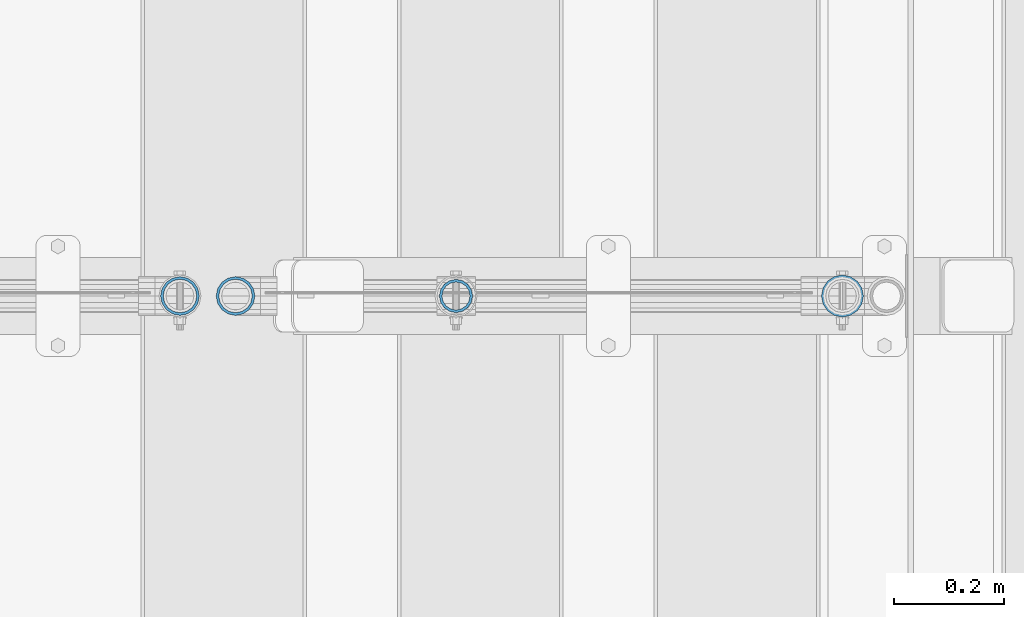
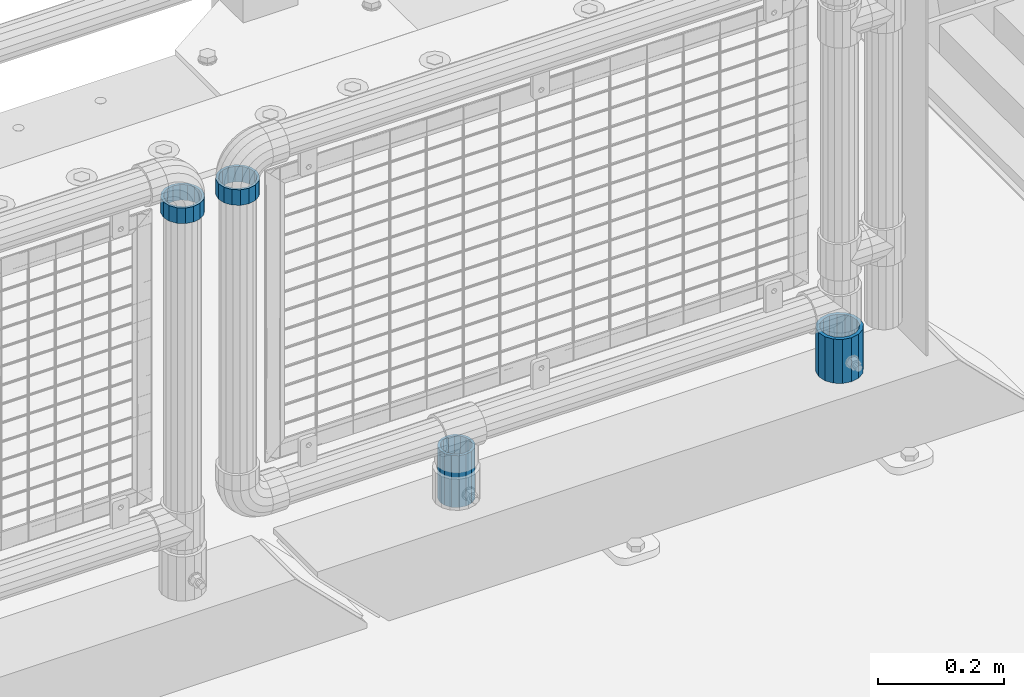
# One storey, part 104 of 247: 4 columns.
"""IFC2X3 building model written with IfcOpenShell, lengths in millimetres."""

from ifc_helpers import new_model, si_unit, frame, origin_with_axes, place, context, subcontext, project, spatial, faceted_brep, material, type_object, element, save


model = new_model("IFC2X3")

# Units and contexts
model_context = context("Model", 3, precision=1e-05, world=origin_with_axes())
body_context = subcontext(model_context, "Body", "Model", "MODEL_VIEW")
ifc_project = project(units=[si_unit("LENGTHUNIT", "METRE", prefix="MILLI"), si_unit("AREAUNIT", "SQUARE_METRE"), si_unit("VOLUMEUNIT", "CUBIC_METRE"), si_unit("MASSUNIT", "GRAM", prefix="KILO"), si_unit("TIMEUNIT", "SECOND"), si_unit("PLANEANGLEUNIT", "RADIAN"), si_unit("SOLIDANGLEUNIT", "STERADIAN"), si_unit("THERMODYNAMICTEMPERATUREUNIT", "DEGREE_CELSIUS"), si_unit("LUMINOUSINTENSITYUNIT", "LUMEN")], contexts=[model_context])

# Site, building, storey
site_placement = place(None, origin_with_axes())
site = spatial("IfcSite", under=ifc_project, at=site_placement, CompositionType="ELEMENT")
building_placement = place(site_placement, origin_with_axes())
building = spatial("IfcBuilding", under=site, at=building_placement, Name="Standard", CompositionType="ELEMENT")
storey_placement = place(building_placement, origin_with_axes())
storey = spatial("IfcBuildingStorey", under=building, at=storey_placement, Name="Undefined", CompositionType="ELEMENT", Elevation=0.0)

# Columns
ifc_material_1 = material()
column_type_1 = type_object("IfcColumnType", PredefinedType="NOTDEFINED")
column_1_placement = place(storey_placement, frame((16221.0, 7664.5, 168.019999999998), z_axis=(0.0, 1.0, 0.0), x_axis=(0.0, 0.0, 1.0)))
element("IfcColumn", 1, at=column_1_placement, inside=storey, type_object=column_type_1, material=ifc_material_1, context=body_context, shape_type="Brep", body=[
    faceted_brep([(0.0, -31.75, 0.0), (0.0, -29.3331751572332, 12.1501989775916), (85.0, -29.3331751572332, 12.1501989775916), (85.0, -31.75, 0.0), (0.0, -22.4506403026735, 22.4506403026726), (85.0, -22.4506403026735, 22.4506403026726), (0.0, -12.1501989775916, 29.3331751572332), (85.0, -12.1501989775916, 29.3331751572332), (0.0, 0.0, 31.75), (85.0, 0.0, 31.75), (0.0, 12.1501989775916, 29.3331751572332), (85.0, 12.1501989775916, 29.3331751572332), (0.0, 22.4506403026735, 22.4506403026726), (85.0, 22.4506403026735, 22.4506403026726), (0.0, 29.3331751572332, 12.1501989775916), (85.0, 29.3331751572332, 12.1501989775916), (0.0, 31.75, 0.0), (85.0, 31.75, 0.0), (0.0, 29.3331751572332, -12.1501989775916), (85.0, 29.3331751572332, -12.1501989775916), (0.0, 22.4506403026735, -22.4506403026726), (85.0, 22.4506403026735, -22.4506403026726), (0.0, 12.1501989775916, -29.3331751572332), (85.0, 12.1501989775916, -29.3331751572332), (0.0, 0.0, -31.75), (85.0, 0.0, -31.75), (0.0, -12.1501989775916, -29.3331751572332), (85.0, -12.1501989775916, -29.3331751572332), (0.0, -22.4506403026735, -22.4506403026726), (85.0, -22.4506403026735, -22.4506403026726), (0.0, -29.3331751572332, -12.1501989775916), (85.0, -29.3331751572332, -12.1501989775916), (0.0, -38.0499999999993, 0.0), (0.0, -35.1536162120537, -14.5611046014919), (85.0, -35.1536162120537, -14.5611046014919), (85.0, -38.0499999999993, 0.0), (0.0, -26.9054130241475, -26.9054130241484), (85.0, -26.9054130241475, -26.9054130241484), (0.0, -14.561104601491, -35.1536162120547), (85.0, -14.561104601491, -35.1536162120547), (0.0, 0.0, -38.0500000000002), (85.0, 0.0, -38.0500000000002), (0.0, 14.561104601491, -35.1536162120547), (85.0, 14.561104601491, -35.1536162120547), (0.0, 26.9054130241475, -26.9054130241484), (85.0, 26.9054130241475, -26.9054130241484), (0.0, 35.1536162120537, -14.5611046014919), (85.0, 35.1536162120537, -14.5611046014919), (0.0, 38.0499999999993, 0.0), (85.0, 38.0499999999993, 0.0), (0.0, 35.1536162120537, 14.5611046014919), (85.0, 35.1536162120537, 14.5611046014919), (0.0, 26.9054130241475, 26.9054130241484), (85.0, 26.9054130241475, 26.9054130241484), (0.0, 14.561104601491, 35.1536162120547), (85.0, 14.561104601491, 35.1536162120547), (0.0, 0.0, 38.0500000000002), (85.0, 0.0, 38.0500000000002), (0.0, -14.561104601491, 35.1536162120547), (85.0, -14.561104601491, 35.1536162120547), (0.0, -26.9054130241475, 26.9054130241484), (85.0, -26.9054130241475, 26.9054130241484), (0.0, -35.1536162120537, 14.5611046014919), (85.0, -35.1536162120537, 14.5611046014919)], [[[0, 1, 2, 3]], [[1, 4, 5, 2]], [[4, 6, 7, 5]], [[6, 8, 9, 7]], [[8, 10, 11, 9]], [[10, 12, 13, 11]], [[12, 14, 15, 13]], [[14, 16, 17, 15]], [[16, 18, 19, 17]], [[18, 20, 21, 19]], [[20, 22, 23, 21]], [[22, 24, 25, 23]], [[24, 26, 27, 25]], [[26, 28, 29, 27]], [[28, 30, 31, 29]], [[30, 0, 3, 31]], [[32, 33, 34, 35]], [[33, 36, 37, 34]], [[36, 38, 39, 37]], [[38, 40, 41, 39]], [[40, 42, 43, 41]], [[42, 44, 45, 43]], [[44, 46, 47, 45]], [[46, 48, 49, 47]], [[48, 50, 51, 49]], [[50, 52, 53, 51]], [[52, 54, 55, 53]], [[54, 56, 57, 55]], [[56, 58, 59, 57]], [[58, 60, 61, 59]], [[60, 62, 63, 61]], [[62, 32, 35, 63]], [[37, 39, 41, 43, 45, 47, 49, 51, 53, 55, 57, 59, 61, 63, 35, 34], [5, 7, 9, 11, 13, 15, 17, 19, 21, 23, 25, 27, 29, 31, 3, 2]], [[62, 60, 58, 56, 54, 52, 50, 48, 46, 44, 42, 40, 38, 36, 33, 32], [30, 28, 26, 24, 22, 20, 18, 16, 14, 12, 10, 8, 6, 4, 1, 0]]]),
])
ifc_material_2 = material(Name="Misc_Undefined")
column_type_2 = type_object("IfcColumnType", PredefinedType="NOTDEFINED")
column_2_placement = place(storey_placement, frame((15121.61, 7664.5, 894.849999999999), z_axis=(-1.0, 0.0, 0.0), x_axis=(0.0, 0.0, 1.0)))
element("IfcColumn", 2, at=column_2_placement, inside=storey, type_object=column_type_2, material=ifc_material_2, context=body_context, shape_type="Brep", body=[
    faceted_brep([(0.0, -30.3500000000004, 0.0), (0.0, -28.0397438117179, 11.6144421722802), (30.0, -28.0397438117179, 11.6144421722805), (30.0, -30.3500000000004, 0.0), (0.0, -21.4606908090118, 21.4606908090118), (30.0, -21.4606908090118, 21.4606908090117), (0.0, -11.6144421722802, 28.0397438117179), (30.0, -11.6144421722802, 28.0397438117175), (0.0, 0.0, 30.3500000000004), (30.0, 0.0, 30.35), (0.0, 11.6144421722802, 28.0397438117179), (30.0, 11.6144421722802, 28.0397438117175), (0.0, 21.4606908090118, 21.4606908090118), (30.0, 21.4606908090118, 21.4606908090117), (0.0, 28.0397438117179, 11.6144421722802), (30.0, 28.0397438117179, 11.6144421722805), (0.0, 30.3500000000004, 0.0), (30.0, 30.3500000000004, 0.0), (0.0, 28.0397438117179, -11.6144421722802), (30.0, 28.0397438117179, -11.6144421722805), (0.0, 21.4606908090118, -21.4606908090118), (30.0, 21.4606908090118, -21.4606908090117), (0.0, 11.6144421722802, -28.0397438117179), (30.0, 11.6144421722802, -28.0397438117175), (0.0, 0.0, -30.3500000000004), (30.0, 0.0, -30.35), (0.0, -11.6144421722802, -28.0397438117179), (30.0, -11.6144421722802, -28.0397438117175), (0.0, -21.4606908090118, -21.4606908090118), (30.0, -21.4606908090118, -21.4606908090117), (0.0, -28.0397438117179, -11.6144421722802), (30.0, -28.0397438117179, -11.6144421722805), (0.0, -35.1499999999996, 0.0), (0.0, -32.4743655677721, -13.4513226476338), (30.0, -32.4743655677721, -13.4513226476329), (30.0, -35.1499999999996, 0.0), (0.0, -24.8548033587067, -24.8548033587067), (30.0, -24.8548033587067, -24.8548033587072), (0.0, -13.4513226476329, -32.4743655677721), (30.0, -13.4513226476329, -32.4743655677717), (0.0, 0.0, -35.1499999999996), (30.0, 0.0, -35.15), (0.0, 13.4513226476329, -32.4743655677721), (30.0, 13.4513226476329, -32.4743655677717), (0.0, 24.8548033587067, -24.8548033587067), (30.0, 24.8548033587067, -24.8548033587072), (0.0, 32.4743655677721, -13.4513226476338), (30.0, 32.4743655677721, -13.4513226476329), (0.0, 35.1499999999996, 0.0), (30.0, 35.1499999999996, 0.0), (0.0, 32.4743655677721, 13.4513226476338), (30.0, 32.4743655677721, 13.4513226476329), (0.0, 24.8548033587067, 24.8548033587067), (30.0, 24.8548033587067, 24.8548033587072), (0.0, 13.4513226476329, 32.4743655677721), (30.0, 13.4513226476329, 32.4743655677717), (0.0, 0.0, 35.1499999999996), (30.0, 0.0, 35.15), (0.0, -13.4513226476329, 32.4743655677721), (30.0, -13.4513226476329, 32.4743655677717), (0.0, -24.8548033587067, 24.8548033587067), (30.0, -24.8548033587067, 24.8548033587072), (0.0, -32.4743655677721, 13.4513226476338), (30.0, -32.4743655677721, 13.4513226476329)], [[[0, 1, 2, 3]], [[1, 4, 5, 2]], [[4, 6, 7, 5]], [[6, 8, 9, 7]], [[8, 10, 11, 9]], [[10, 12, 13, 11]], [[12, 14, 15, 13]], [[14, 16, 17, 15]], [[16, 18, 19, 17]], [[18, 20, 21, 19]], [[20, 22, 23, 21]], [[22, 24, 25, 23]], [[24, 26, 27, 25]], [[26, 28, 29, 27]], [[28, 30, 31, 29]], [[30, 0, 3, 31]], [[32, 33, 34, 35]], [[33, 36, 37, 34]], [[36, 38, 39, 37]], [[38, 40, 41, 39]], [[40, 42, 43, 41]], [[42, 44, 45, 43]], [[44, 46, 47, 45]], [[46, 48, 49, 47]], [[48, 50, 51, 49]], [[50, 52, 53, 51]], [[52, 54, 55, 53]], [[54, 56, 57, 55]], [[56, 58, 59, 57]], [[58, 60, 61, 59]], [[60, 62, 63, 61]], [[62, 32, 35, 63]], [[37, 39, 41, 43, 45, 47, 49, 51, 53, 55, 57, 59, 61, 63, 35, 34], [5, 7, 9, 11, 13, 15, 17, 19, 21, 23, 25, 27, 29, 31, 3, 2]], [[62, 60, 58, 56, 54, 52, 50, 48, 46, 44, 42, 40, 38, 36, 33, 32], [30, 28, 26, 24, 22, 20, 18, 16, 14, 12, 10, 8, 6, 4, 1, 0]]]),
])
column_3_placement = place(storey_placement, frame((15021.0, 7664.5, 894.85), z_axis=(1.0, 0.0, 0.0), x_axis=(0.0, 0.0, 1.0)))
element("IfcColumn", 3, at=column_3_placement, inside=storey, type_object=column_type_2, material=ifc_material_2, context=body_context, shape_type="Brep", body=[
    faceted_brep([(0.0, -30.3500000000004, 0.0), (0.0, -28.0397438117179, 11.6144421722802), (30.0, -28.0397438117179, 11.6144421722805), (30.0, -30.3500000000004, 0.0), (0.0, -21.4606908090118, 21.4606908090118), (30.0, -21.4606908090118, 21.4606908090117), (0.0, -11.6144421722802, 28.0397438117179), (30.0, -11.6144421722802, 28.0397438117175), (0.0, 0.0, 30.3500000000004), (30.0, 0.0, 30.35), (0.0, 11.6144421722802, 28.0397438117179), (30.0, 11.6144421722802, 28.0397438117175), (0.0, 21.4606908090118, 21.4606908090118), (30.0, 21.4606908090118, 21.4606908090117), (0.0, 28.0397438117179, 11.6144421722802), (30.0, 28.0397438117179, 11.6144421722805), (0.0, 30.3500000000004, 0.0), (30.0, 30.3500000000004, 0.0), (0.0, 28.0397438117179, -11.6144421722802), (30.0, 28.0397438117179, -11.6144421722805), (0.0, 21.4606908090118, -21.4606908090118), (30.0, 21.4606908090118, -21.4606908090117), (0.0, 11.6144421722802, -28.0397438117179), (30.0, 11.6144421722802, -28.0397438117175), (0.0, 0.0, -30.3500000000004), (30.0, 0.0, -30.35), (0.0, -11.6144421722802, -28.0397438117179), (30.0, -11.6144421722802, -28.0397438117175), (0.0, -21.4606908090118, -21.4606908090118), (30.0, -21.4606908090118, -21.4606908090117), (0.0, -28.0397438117179, -11.6144421722802), (30.0, -28.0397438117179, -11.6144421722805), (0.0, -35.1499999999996, 0.0), (0.0, -32.4743655677721, -13.4513226476338), (30.0, -32.4743655677721, -13.4513226476329), (30.0, -35.1499999999996, 0.0), (0.0, -24.8548033587067, -24.8548033587067), (30.0, -24.8548033587067, -24.8548033587072), (0.0, -13.4513226476329, -32.4743655677721), (30.0, -13.4513226476329, -32.4743655677717), (0.0, 0.0, -35.1499999999996), (30.0, 0.0, -35.15), (0.0, 13.4513226476329, -32.4743655677721), (30.0, 13.4513226476329, -32.4743655677717), (0.0, 24.8548033587067, -24.8548033587067), (30.0, 24.8548033587067, -24.8548033587072), (0.0, 32.4743655677721, -13.4513226476338), (30.0, 32.4743655677721, -13.4513226476329), (0.0, 35.1499999999996, 0.0), (30.0, 35.1499999999996, 0.0), (0.0, 32.4743655677721, 13.4513226476338), (30.0, 32.4743655677721, 13.4513226476329), (0.0, 24.8548033587067, 24.8548033587067), (30.0, 24.8548033587067, 24.8548033587072), (0.0, 13.4513226476329, 32.4743655677721), (30.0, 13.4513226476329, 32.4743655677717), (0.0, 0.0, 35.1499999999996), (30.0, 0.0, 35.15), (0.0, -13.4513226476329, 32.4743655677721), (30.0, -13.4513226476329, 32.4743655677717), (0.0, -24.8548033587067, 24.8548033587067), (30.0, -24.8548033587067, 24.8548033587072), (0.0, -32.4743655677721, 13.4513226476338), (30.0, -32.4743655677721, 13.4513226476329)], [[[0, 1, 2, 3]], [[1, 4, 5, 2]], [[4, 6, 7, 5]], [[6, 8, 9, 7]], [[8, 10, 11, 9]], [[10, 12, 13, 11]], [[12, 14, 15, 13]], [[14, 16, 17, 15]], [[16, 18, 19, 17]], [[18, 20, 21, 19]], [[20, 22, 23, 21]], [[22, 24, 25, 23]], [[24, 26, 27, 25]], [[26, 28, 29, 27]], [[28, 30, 31, 29]], [[30, 0, 3, 31]], [[32, 33, 34, 35]], [[33, 36, 37, 34]], [[36, 38, 39, 37]], [[38, 40, 41, 39]], [[40, 42, 43, 41]], [[42, 44, 45, 43]], [[44, 46, 47, 45]], [[46, 48, 49, 47]], [[48, 50, 51, 49]], [[50, 52, 53, 51]], [[52, 54, 55, 53]], [[54, 56, 57, 55]], [[56, 58, 59, 57]], [[58, 60, 61, 59]], [[60, 62, 63, 61]], [[62, 32, 35, 63]], [[37, 39, 41, 43, 45, 47, 49, 51, 53, 55, 57, 59, 61, 63, 35, 34], [5, 7, 9, 11, 13, 15, 17, 19, 21, 23, 25, 27, 29, 31, 3, 2]], [[62, 60, 58, 56, 54, 52, 50, 48, 46, 44, 42, 40, 38, 36, 33, 32], [30, 28, 26, 24, 22, 20, 18, 16, 14, 12, 10, 8, 6, 4, 1, 0]]]),
])
column_type_3 = type_object("IfcColumnType", PredefinedType="NOTDEFINED")
column_4_placement = place(storey_placement, frame((15521.0, 7664.5, 168.019999999998), z_axis=(-1.0, 0.0, 0.0), x_axis=(0.0, 0.0, 1.0)))
element("IfcColumn", 4, at=column_4_placement, inside=storey, type_object=column_type_3, material=ifc_material_1, context=body_context, shape_type="Brep", body=[
    faceted_brep([(0.0, -25.3500000000004, 0.0), (0.0, -23.4203461491616, 9.70102501045585), (100.0, -23.4203461491616, 9.70102501045585), (100.0, -25.3500000000004, 0.0), (0.0, -17.9251569030794, 17.9251569030785), (100.0, -17.9251569030794, 17.9251569030785), (0.0, -9.70102501045494, 23.4203461491616), (100.0, -9.70102501045494, 23.4203461491616), (0.0, 0.0, 25.3500000000004), (100.0, 0.0, 25.3500000000004), (0.0, 9.70102501045494, 23.4203461491616), (100.0, 9.70102501045494, 23.4203461491616), (0.0, 17.9251569030794, 17.9251569030785), (100.0, 17.9251569030794, 17.9251569030785), (0.0, 23.4203461491616, 9.70102501045585), (100.0, 23.4203461491616, 9.70102501045585), (0.0, 25.3500000000004, 0.0), (100.0, 25.3500000000004, 0.0), (0.0, 23.4203461491616, -9.70102501045585), (100.0, 23.4203461491616, -9.70102501045585), (0.0, 17.9251569030794, -17.9251569030785), (100.0, 17.9251569030794, -17.9251569030785), (0.0, 9.70102501045494, -23.4203461491616), (100.0, 9.70102501045494, -23.4203461491616), (0.0, 0.0, -25.3500000000004), (100.0, 0.0, -25.3500000000004), (0.0, -9.70102501045494, -23.4203461491616), (100.0, -9.70102501045494, -23.4203461491616), (0.0, -17.9251569030794, -17.9251569030785), (100.0, -17.9251569030794, -17.9251569030785), (0.0, -23.4203461491616, -9.70102501045585), (100.0, -23.4203461491616, -9.70102501045585), (0.0, -30.1499999999996, 0.0), (0.0, -27.8549679052148, -11.5379054858076), (100.0, -27.8549679052148, -11.5379054858076), (100.0, -30.1499999999996, 0.0), (0.0, -21.3192694527743, -21.3192694527752), (100.0, -21.3192694527743, -21.3192694527752), (0.0, -11.5379054858076, -27.8549679052157), (100.0, -11.5379054858076, -27.8549679052157), (0.0, 0.0, -30.1499999999996), (100.0, 0.0, -30.1499999999996), (0.0, 11.5379054858076, -27.8549679052157), (100.0, 11.5379054858076, -27.8549679052157), (0.0, 21.3192694527743, -21.3192694527752), (100.0, 21.3192694527743, -21.3192694527752), (0.0, 27.8549679052157, -11.5379054858076), (100.0, 27.8549679052157, -11.5379054858076), (0.0, 30.1499999999996, 0.0), (100.0, 30.1499999999996, 0.0), (0.0, 27.8549679052157, 11.5379054858076), (100.0, 27.8549679052157, 11.5379054858076), (0.0, 21.3192694527743, 21.3192694527752), (100.0, 21.3192694527743, 21.3192694527752), (0.0, 11.5379054858076, 27.8549679052157), (100.0, 11.5379054858076, 27.8549679052157), (0.0, 0.0, 30.1499999999996), (100.0, 0.0, 30.1499999999996), (0.0, -11.5379054858076, 27.8549679052157), (100.0, -11.5379054858076, 27.8549679052157), (0.0, -21.3192694527743, 21.3192694527752), (100.0, -21.3192694527743, 21.3192694527752), (0.0, -27.8549679052157, 11.5379054858076), (100.0, -27.8549679052157, 11.5379054858076)], [[[0, 1, 2, 3]], [[1, 4, 5, 2]], [[4, 6, 7, 5]], [[6, 8, 9, 7]], [[8, 10, 11, 9]], [[10, 12, 13, 11]], [[12, 14, 15, 13]], [[14, 16, 17, 15]], [[16, 18, 19, 17]], [[18, 20, 21, 19]], [[20, 22, 23, 21]], [[22, 24, 25, 23]], [[24, 26, 27, 25]], [[26, 28, 29, 27]], [[28, 30, 31, 29]], [[30, 0, 3, 31]], [[32, 33, 34, 35]], [[33, 36, 37, 34]], [[36, 38, 39, 37]], [[38, 40, 41, 39]], [[40, 42, 43, 41]], [[42, 44, 45, 43]], [[44, 46, 47, 45]], [[46, 48, 49, 47]], [[48, 50, 51, 49]], [[50, 52, 53, 51]], [[52, 54, 55, 53]], [[54, 56, 57, 55]], [[56, 58, 59, 57]], [[58, 60, 61, 59]], [[60, 62, 63, 61]], [[62, 32, 35, 63]], [[37, 39, 41, 43, 45, 47, 49, 51, 53, 55, 57, 59, 61, 63, 35, 34], [5, 7, 9, 11, 13, 15, 17, 19, 21, 23, 25, 27, 29, 31, 3, 2]], [[62, 60, 58, 56, 54, 52, 50, 48, 46, 44, 42, 40, 38, 36, 33, 32], [30, 28, 26, 24, 22, 20, 18, 16, 14, 12, 10, 8, 6, 4, 1, 0]]]),
])

save(model, "model.ifc")
